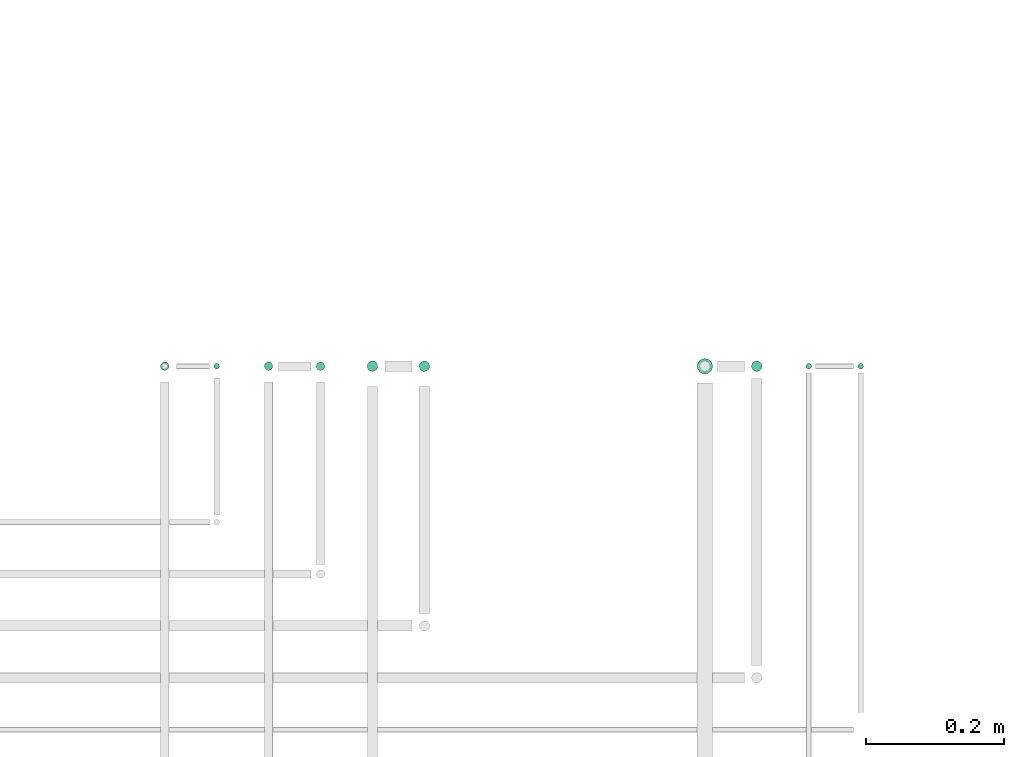
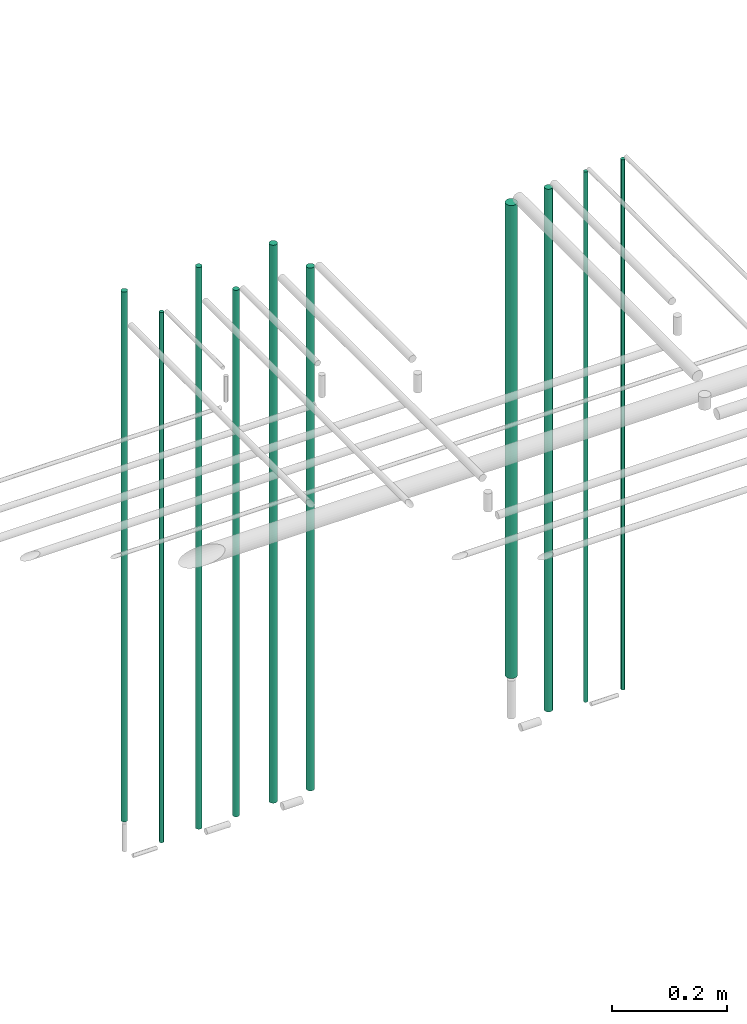
# One storey, part 4 of 65: 10 flow segments.
"""IFC2X3 building model written with IfcOpenShell, lengths in millimetres."""

from ifc_helpers import new_model, entity, si_unit, converted_unit, derived_unit, direction, frame, frame_2d, origin, origin_2d_with_axis, place, context, subcontext, project, spatial, circle, extrude, type_object, element, save


model = new_model("IFC2X3")

# Units and contexts
model_context = context("Model", 3, precision=0.01, world=origin(), true_north=direction((6.12303176911189e-17, 1.0)))
body_context = subcontext(model_context, "Body", "Model", "MODEL_VIEW")
ifc_project = project(units=[si_unit("LENGTHUNIT", "METRE", prefix="MILLI"), si_unit("AREAUNIT", "SQUARE_METRE"), si_unit("VOLUMEUNIT", "CUBIC_METRE"), converted_unit("PLANEANGLEUNIT", "DEGREE", entity("IfcRatioMeasure", 0.0174532925199433), si_unit("PLANEANGLEUNIT", "RADIAN"), dimensions=[0, 0, 0, 0, 0, 0, 0]), si_unit("MASSUNIT", "GRAM", prefix="KILO"), derived_unit("MASSDENSITYUNIT", [(si_unit("MASSUNIT", "GRAM", prefix="KILO"), 1), (si_unit("LENGTHUNIT", "METRE"), -3)]), derived_unit("MOMENTOFINERTIAUNIT", [(si_unit("LENGTHUNIT", "METRE"), 4)]), si_unit("TIMEUNIT", "SECOND"), si_unit("FREQUENCYUNIT", "HERTZ"), si_unit("THERMODYNAMICTEMPERATUREUNIT", "DEGREE_CELSIUS"), derived_unit("THERMALTRANSMITTANCEUNIT", [(si_unit("MASSUNIT", "GRAM", prefix="KILO"), 1), (si_unit("THERMODYNAMICTEMPERATUREUNIT", "KELVIN"), -1), (si_unit("TIMEUNIT", "SECOND"), -3)]), derived_unit("VOLUMETRICFLOWRATEUNIT", [(si_unit("LENGTHUNIT", "METRE"), 3), (si_unit("TIMEUNIT", "SECOND"), -1)]), derived_unit("MASSFLOWRATEUNIT", [(si_unit("MASSUNIT", "GRAM", prefix="KILO"), 1), (si_unit("TIMEUNIT", "SECOND"), -1)]), derived_unit("ROTATIONALFREQUENCYUNIT", [(si_unit("TIMEUNIT", "SECOND"), -1)]), si_unit("ELECTRICCURRENTUNIT", "AMPERE"), si_unit("ELECTRICVOLTAGEUNIT", "VOLT"), si_unit("POWERUNIT", "WATT"), si_unit("FORCEUNIT", "NEWTON", prefix="KILO"), si_unit("ILLUMINANCEUNIT", "LUX"), si_unit("LUMINOUSFLUXUNIT", "LUMEN"), si_unit("LUMINOUSINTENSITYUNIT", "CANDELA"), derived_unit("USERDEFINED", [(si_unit("MASSUNIT", "GRAM", prefix="KILO"), -1), (si_unit("LENGTHUNIT", "METRE"), -2), (si_unit("TIMEUNIT", "SECOND"), 3), (si_unit("LUMINOUSFLUXUNIT", "LUMEN"), 1)]), derived_unit("LINEARVELOCITYUNIT", [(si_unit("LENGTHUNIT", "METRE"), 1), (si_unit("TIMEUNIT", "SECOND"), -1)]), si_unit("PRESSUREUNIT", "PASCAL"), derived_unit("USERDEFINED", [(si_unit("LENGTHUNIT", "METRE"), -2), (si_unit("MASSUNIT", "GRAM", prefix="KILO"), 1), (si_unit("TIMEUNIT", "SECOND"), -2)]), derived_unit("LINEARFORCEUNIT", [(si_unit("MASSUNIT", "GRAM", prefix="KILO"), 1), (si_unit("LENGTHUNIT", "METRE"), 1), (si_unit("TIMEUNIT", "SECOND"), -2), (si_unit("LENGTHUNIT", "METRE"), -1)]), derived_unit("PLANARFORCEUNIT", [(si_unit("MASSUNIT", "GRAM", prefix="KILO"), 1), (si_unit("LENGTHUNIT", "METRE"), 1), (si_unit("TIMEUNIT", "SECOND"), -2), (si_unit("LENGTHUNIT", "METRE"), -2)])], contexts=[model_context])

# Site, building, storey
site_placement = place(None, frame((0.0, -0.00077364408347762, 0.0)))
site = spatial("IfcSite", under=ifc_project, at=site_placement, CompositionType="ELEMENT")
building_placement = place(site_placement, origin())
building = spatial("IfcBuilding", under=site, at=building_placement, CompositionType="ELEMENT")
storey_placement = place(building_placement, frame((0.0, 0.0, 19800.0)))
storey = spatial("IfcBuildingStorey", under=building, at=storey_placement, CompositionType="ELEMENT", Elevation=19800.0)

# Flow segments
pipe_segment_type = type_object("IfcPipeSegmentType", PredefinedType="NOTDEFINED")
flow_segment_1_placement = place(storey_placement, frame((43448.1765221717, 7490.9047277641, 1418.0)))
element("IfcFlowSegment", 1, at=flow_segment_1_placement, inside=storey, type_object=pipe_segment_type, context=body_context, shape_type="SweptSolid", body=[
    extrude(circle(Radius=7.5, at=origin_2d_with_axis()), frame((9.09527223591419, 9.09527223591636, 0.0)), (0.0, 0.0, 1.0), 1114.00000000002),
])
flow_segment_2_placement = place(storey_placement, frame((43369.6765221717, 7487.4047277641, 1518.0)))
element("IfcFlowSegment", 2, at=flow_segment_2_placement, inside=storey, type_object=pipe_segment_type, context=body_context, shape_type="SweptSolid", body=[
    extrude(circle(Radius=11.0, at=origin_2d_with_axis()), frame((12.5952722359134, 12.5952722359156, 0.0)), (0.0, 0.0, 1.0), 1007.99999999997),
])
flow_segment_3_placement = place(storey_placement, frame((43601.6765221717, 7494.4047277641, 1410.0)))
element("IfcFlowSegment", 3, at=flow_segment_3_placement, inside=storey, type_object=pipe_segment_type, context=body_context, shape_type="SweptSolid", body=[
    extrude(circle(Radius=4.0, at=origin_2d_with_axis()), frame((5.59527223591499, 5.59527223591607, 0.0)), (0.0, 0.0, 1.0), 1130.00000000001),
])
flow_segment_4_placement = place(storey_placement, frame((43526.6765221717, 7494.40472776409, 1410.0)))
element("IfcFlowSegment", 4, at=flow_segment_4_placement, inside=storey, type_object=pipe_segment_type, context=body_context, shape_type="SweptSolid", body=[
    extrude(circle(Radius=4.0, at=origin_2d_with_axis()), frame((5.59527223591499, 5.59527223591607, 0.0), z_axis=(0.0, 0.0, 1.0), x_axis=(-1.0, 0.0, 0.0)), (0.0, 0.0, 1.0), 1130.0),
])
flow_segment_5_placement = place(storey_placement, frame((42968.1765221717, 7490.90472776409, 1418.0)))
element("IfcFlowSegment", 5, at=flow_segment_5_placement, inside=storey, type_object=pipe_segment_type, context=body_context, shape_type="SweptSolid", body=[
    extrude(circle(Radius=7.5, at=origin_2d_with_axis()), frame((9.09527223591419, 9.09527223591636, 0.0)), (0.0, 0.0, 1.0), 1114.00000000001),
])
flow_segment_6_placement = place(storey_placement, frame((42893.1765221717, 7490.90472776408, 1418.0)))
element("IfcFlowSegment", 6, at=flow_segment_6_placement, inside=storey, type_object=pipe_segment_type, context=body_context, shape_type="SweptSolid", body=[
    extrude(circle(Radius=7.5, at=origin_2d_with_axis()), frame((9.09527223591419, 9.09527223591636, 0.0), z_axis=(0.0, 0.0, 1.0), x_axis=(-1.0, 0.0, 0.0)), (0.0, 0.0, 1.0), 1189.0),
])
flow_segment_7_placement = place(storey_placement, frame((42819.6765221717, 7492.40472776409, 1414.0)))
element("IfcFlowSegment", 7, at=flow_segment_7_placement, inside=storey, type_object=pipe_segment_type, context=body_context, shape_type="SweptSolid", body=[
    extrude(circle(Radius=6.0, at=origin_2d_with_axis()), frame((7.59527223591454, 7.59527223591562, 0.0)), (0.0, 0.0, 1.0), 1122.00000000001),
])
flow_segment_8_placement = place(storey_placement, frame((42744.6765221717, 7492.40472776408, 1414.0)))
element("IfcFlowSegment", 8, at=flow_segment_8_placement, inside=storey, type_object=pipe_segment_type, context=body_context, shape_type="SweptSolid", body=[
    extrude(circle(Radius=6.0, at=frame_2d((0.0, -1.08286712929839e-12), x_axis=(1.0, 0.0))), frame((7.59527223591454, 7.59527223591454, 0.0), z_axis=(0.0, 0.0, 1.0), x_axis=(-1.0, 0.0, 0.0)), (0.0, 0.0, 1.0), 1197.0),
])
flow_segment_9_placement = place(storey_placement, frame((42671.6765221717, 7494.40472776409, 1410.0)))
element("IfcFlowSegment", 9, at=flow_segment_9_placement, inside=storey, type_object=pipe_segment_type, context=body_context, shape_type="SweptSolid", body=[
    extrude(circle(Radius=4.0, at=origin_2d_with_axis()), frame((5.59527223591499, 5.59527223591607, 0.0)), (0.0, 0.0, 1.0), 1130.00000000001),
])
flow_segment_10_placement = place(storey_placement, frame((42594.6765221717, 7492.40472776408, 1482.0)))
element("IfcFlowSegment", 10, at=flow_segment_10_placement, inside=storey, type_object=pipe_segment_type, context=body_context, shape_type="SweptSolid", body=[
    extrude(circle(Radius=6.0, at=frame_2d((0.0, -1.08286712929839e-12), x_axis=(1.0, 0.0))), frame((7.59527223591454, 7.59527223591454, 0.0), z_axis=(0.0, 0.0, 1.0), x_axis=(-1.0, 0.0, 0.0)), (0.0, 0.0, 1.0), 1129.0),
])

save(model, "model.ifc")
